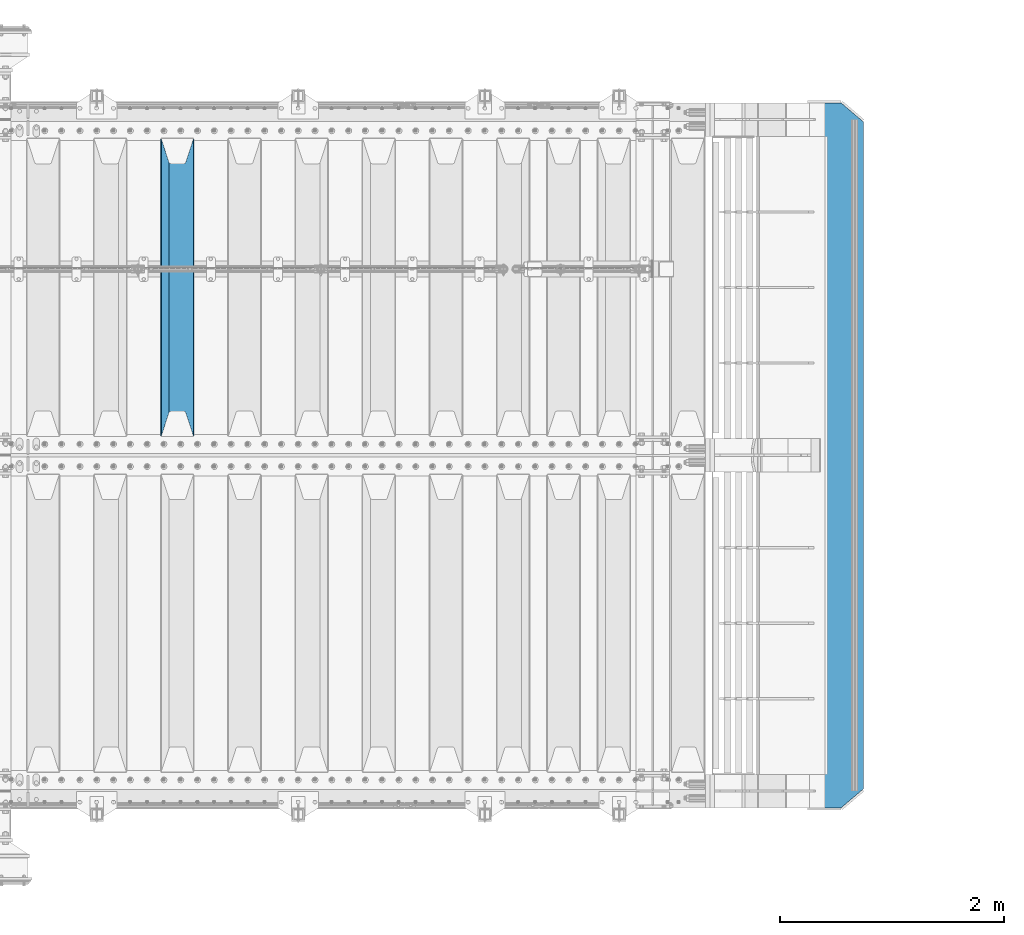
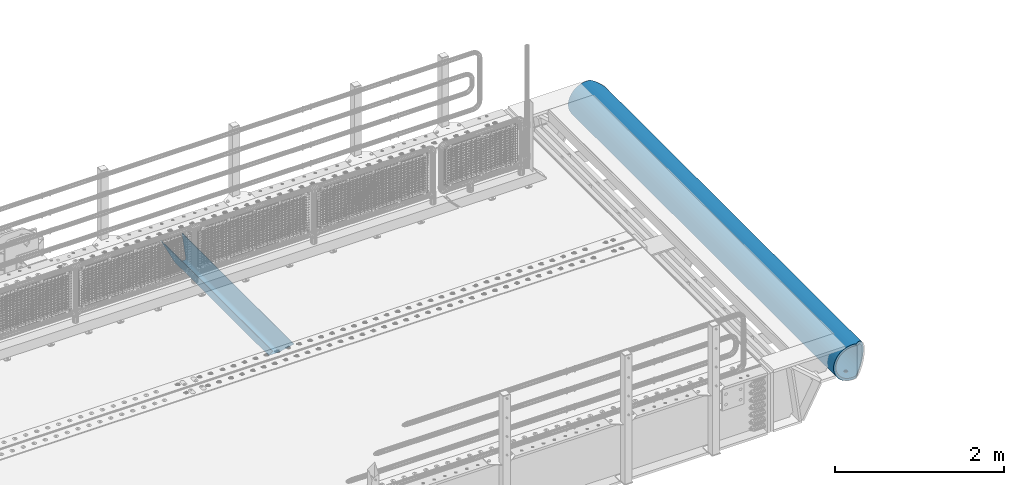
# One storey, part 132 of 242: 2 beams.
"""IFC2X3 building model written with IfcOpenShell, lengths in millimetres."""

from ifc_helpers import new_model, si_unit, frame, origin_with_axes, place, context, subcontext, project, spatial, faceted_brep, material, type_object, element, save


model = new_model("IFC2X3")

# Units and contexts
model_context = context("Model", 3, precision=1e-05, world=origin_with_axes())
body_context = subcontext(model_context, "Body", "Model", "MODEL_VIEW")
ifc_project = project(units=[si_unit("LENGTHUNIT", "METRE", prefix="MILLI"), si_unit("AREAUNIT", "SQUARE_METRE"), si_unit("VOLUMEUNIT", "CUBIC_METRE"), si_unit("MASSUNIT", "GRAM", prefix="KILO"), si_unit("TIMEUNIT", "SECOND"), si_unit("PLANEANGLEUNIT", "RADIAN"), si_unit("SOLIDANGLEUNIT", "STERADIAN"), si_unit("THERMODYNAMICTEMPERATUREUNIT", "DEGREE_CELSIUS"), si_unit("LUMINOUSINTENSITYUNIT", "LUMEN")], contexts=[model_context])

# Site, building, storey
site_placement = place(None, origin_with_axes())
site = spatial("IfcSite", under=ifc_project, at=site_placement, CompositionType="ELEMENT")
building_placement = place(site_placement, origin_with_axes())
building = spatial("IfcBuilding", under=site, at=building_placement, Name="Standard", CompositionType="ELEMENT")
storey_placement = place(building_placement, origin_with_axes())
storey = spatial("IfcBuildingStorey", under=building, at=storey_placement, Name="Undefined", CompositionType="ELEMENT", Elevation=0.0)

# Beams
ifc_material = material(Name="STEEL/S355N")
beam_type_1 = type_object("IfcBeamType", PredefinedType="NOTDEFINED")
beam_1_placement = place(storey_placement, frame((-26780.0, -20825.0, -115.0), z_axis=(0.0, 0.0, 1.0), x_axis=(0.0, 1.0, 0.0)))
element("IfcBeam", 1, at=beam_1_placement, inside=storey, type_object=beam_type_1, material=ifc_material, context=body_context, shape_type="Brep", body=[
    faceted_brep([(0.0, 150.0, 115.0), (0.0, 143.689999999999, 115.0), (2650.00000000297, 143.689999999999, 115.0), (2650.00000000297, 150.0, 115.0), (2650.00000000297, 142.059565218402, 110.000000003099), (2650.00000000297, 148.369565218403, 110.000000003099), (2441.90079219209, -80.1103600731112, -98.0992078077845), (2437.7588105432, -77.5672621345584, -102.241189456673), (2434.06523489747, -74.4080125315522, -105.934765102404), (2430.91086095089, -70.710272125576, -109.089139048974), (2428.37322971128, -66.5649389910068, -111.626770288588), (2426.51472138055, -62.0739139532889, -113.485278619323), (2425.38102192092, -57.3475956567672, -114.618978078955), (2424.99999999987, -52.5021667386536, -115.0), (2424.99999999987, 52.5021667386536, -115.0), (2425.38102192092, 57.3475956567672, -114.618978078955), (2426.51472138055, 62.0739139532889, -113.485278619323), (2428.37322971128, 66.5649389910068, -111.626770288588), (2430.91086095089, 70.710272125576, -109.089139048974), (2434.06523489747, 74.4080125315522, -105.934765102404), (2437.7588105432, 77.5672621345584, -102.241189456673), (2441.90079219209, 80.1103600731112, -98.0992078077846), (2446.38936140511, 81.9747917625791, -93.6106385947584), (2448.2494850041, 76.2713538057251, -91.7505149957729), (2444.62967112262, 74.76777986261, -95.3703288772456), (2441.28936334126, 72.7168944282894, -98.710636658607), (2438.31067330438, 70.1691124903846, -101.689326695487), (2435.76682334747, 67.1870637758839, -104.233176652398), (2433.72034654133, 63.8440531834895, -106.279653458539), (2432.22154950042, 60.222258798236, -107.778450499454), (2431.30727574265, 56.4107117849089, -108.692724257221), (2430.99999999987, 52.5031078186876, -109.0), (2430.99999999987, -52.5031078186876, -109.0), (2431.30727574265, -56.4107117849089, -108.692724257221), (2432.22154950042, -60.222258798236, -107.778450499454), (2433.72034654133, -63.8440531834895, -106.279653458539), (2435.76682334747, -67.1870637758839, -104.233176652398), (2438.31067330438, -70.1691124903846, -101.689326695487), (2441.28936334126, -72.7168944282894, -98.7106366586071), (2444.62967112262, -74.76777986261, -95.3703288772457), (2448.2494850041, -76.2713538057251, -91.7505149957729), (2650.00000000297, -142.059565218402, 110.000000003099), (2650.00000000297, -148.369565218403, 110.000000003099), (2446.38936140511, -81.9747917625791, -93.6106385947584), (2650.00000000297, -143.689999999999, 115.0), (2650.00000000297, -150.0, 115.0), (0.0, -143.689999999999, 115.0), (0.0, -150.0, 115.0), (0.0, -148.369565218261, 110.000000002669), (203.610638597427, -81.9747917625791, -93.6106385947584), (208.099207810454, -80.1103600731112, -98.0992078077845), (212.241189459342, -77.5672621345584, -102.241189456673), (215.934765105074, -74.4080125315522, -105.934765102404), (219.089139051644, -70.710272125576, -109.089139048974), (221.626770291256, -66.5649389910068, -111.626770288588), (223.485278621993, -62.0739139532889, -113.485278619323), (224.618978081624, -57.3475956567672, -114.618978078955), (225.00000000267, -52.5021667386536, -115.0), (225.00000000267, 52.5021667386536, -115.0), (224.618978081624, 57.3475956567672, -114.618978078955), (223.485278621993, 62.0739139532889, -113.485278619323), (221.626770291256, 66.5649389910068, -111.626770288588), (219.089139051644, 70.710272125576, -109.089139048974), (215.934765105074, 74.4080125315522, -105.934765102404), (212.241189459342, 77.5672621345584, -102.241189456673), (208.099207810454, 80.1103600731112, -98.0992078077846), (203.610638597427, 81.9747917625791, -93.6106385947584), (0.0, 148.369565218261, 110.000000002669), (0.0, 142.05956521826, 110.000000002669), (201.750514998443, 76.2713538057251, -91.7505149957729), (205.370328879915, 74.76777986261, -95.3703288772456), (208.710636661275, 72.7168944282894, -98.710636658607), (211.689326698157, 70.1691124903846, -101.689326695487), (214.233176655067, 67.1870637758839, -104.233176652398), (216.279653461206, 63.8440531834895, -106.279653458539), (217.778450502123, 60.222258798236, -107.778450499454), (218.69272425989, 56.4107117849089, -108.692724257221), (219.00000000267, 52.5031078186876, -109.0), (219.00000000267, -52.5031078186876, -109.0), (218.69272425989, -56.4107117849089, -108.692724257221), (217.778450502123, -60.222258798236, -107.778450499454), (216.279653461206, -63.8440531834895, -106.279653458539), (214.233176655067, -67.1870637758839, -104.233176652398), (211.689326698157, -70.1691124903846, -101.689326695487), (208.710636661275, -72.7168944282894, -98.7106366586071), (205.370328879915, -74.76777986261, -95.3703288772457), (201.750514998443, -76.2713538057251, -91.7505149957729), (0.0, -142.05956521826, 110.000000002669)], [[[0, 1, 2, 3]], [[3, 2, 4, 5]], [[6, 7, 8, 9, 10, 11, 12, 13, 14, 15, 16, 17, 18, 19, 20, 21, 22, 5, 4, 23, 24, 25, 26, 27, 28, 29, 30, 31, 32, 33, 34, 35, 36, 37, 38, 39, 40, 41, 42, 43]], [[44, 45, 42, 41]], [[46, 47, 45, 44]], [[43, 42, 45, 47, 48, 49]], [[6, 43, 49, 50]], [[7, 6, 50, 51]], [[8, 7, 51, 52]], [[9, 8, 52, 53]], [[10, 9, 53, 54]], [[11, 10, 54, 55]], [[12, 11, 55, 56]], [[13, 12, 56, 57]], [[14, 13, 57, 58]], [[15, 14, 58, 59]], [[16, 15, 59, 60]], [[17, 16, 60, 61]], [[18, 17, 61, 62]], [[19, 18, 62, 63]], [[20, 19, 63, 64]], [[21, 20, 64, 65]], [[22, 21, 65, 66]], [[0, 3, 5, 22, 66, 67]], [[1, 0, 67, 68]], [[23, 4, 2, 1, 68, 69]], [[24, 23, 69, 70]], [[25, 24, 70, 71]], [[26, 25, 71, 72]], [[27, 26, 72, 73]], [[28, 27, 73, 74]], [[29, 28, 74, 75]], [[30, 29, 75, 76]], [[31, 30, 76, 77]], [[32, 31, 77, 78]], [[33, 32, 78, 79]], [[34, 33, 79, 80]], [[35, 34, 80, 81]], [[36, 35, 81, 82]], [[37, 36, 82, 83]], [[38, 37, 83, 84]], [[39, 38, 84, 85]], [[40, 39, 85, 86]], [[46, 44, 41, 40, 86, 87]], [[47, 46, 87, 48]], [[86, 85, 84, 83, 82, 81, 80, 79, 78, 77, 76, 75, 74, 73, 72, 71, 70, 69, 68, 67, 66, 65, 64, 63, 62, 61, 60, 59, 58, 57, 56, 55, 54, 53, 52, 51, 50, 49, 48, 87]]]),
])
beam_type_2 = type_object("IfcBeamType", PredefinedType="NOTDEFINED")
beam_2_placement = place(storey_placement, frame((-20904.0011701094, -17850.0, -254.000000000001), z_axis=(0.0, 0.0, 1.0), x_axis=(0.0, -1.0, 0.0)))
element("IfcBeam", 2, at=beam_2_placement, inside=storey, type_object=beam_type_2, material=ifc_material, context=body_context, shape_type="Brep", body=[
    faceted_brep([(4659.56708580913, 23.1006844286749, -220.181936706646), (4659.56708580913, 23.1006844286749, -252.181936706647), (4667.67766952966, 17.6813656455561, -252.608446344705), (4667.67766952966, 17.6813656455561, -220.608446344705), (4673.09698831278, 9.57078192502013, -253.246763126855), (4673.09698831278, 9.57078192502013, -221.246763126855), (4675.0, 0.0, -254.0), (4675.0, 0.0, -222.0), (4673.09698831278, -9.5633896932377, -253.247344908113), (4673.09698831278, -9.5633896932377, -221.247344908113), (4667.67766952966, -17.6739734137736, -252.609028125962), (4667.67766952966, -17.6739734137736, -220.609028125963), (4659.56708580913, -23.0932921968924, -252.182518487904), (4659.56708580913, -23.0932921968924, -220.182518487905), (4650.0, -24.9963038841088, -252.032748220013), (4650.0, -24.9963038841088, -220.032748220014), (4640.43291419087, -23.0932921968924, -252.182518487904), (4640.43291419087, -23.0932921968924, -220.182518487905), (4632.32233047034, -17.6739734137736, -252.609028125962), (4632.32233047034, -17.6739734137736, -220.609028125963), (4626.90301168722, -9.5633896932377, -253.247344908113), (4626.90301168722, -9.5633896932377, -221.247344908113), (4625.0, 0.0, -254.0), (4625.0, 0.0, -222.0), (4626.90301168722, 9.57078192502013, -253.246763126855), (4626.90301168722, 9.57078192502013, -221.246763126855), (4632.32233047034, 17.6813656455561, -252.608446344705), (4632.32233047034, 17.6813656455561, -220.608446344705), (4640.43291419087, 23.1006844286749, -252.181936706647), (4640.43291419087, 23.1006844286749, -220.181936706646), (4650.0, 25.0036961158912, -252.032166438756), (4650.0, 25.0036961158912, -220.032166438756), (1632.32233047034, -17.6776695296612, -220.608737235334), (1632.32233047034, -17.6776695296612, -252.608737235334), (1626.90301168722, -9.56708580912527, -253.247054017484), (1626.90301168722, -9.56708580912527, -221.247054017484), (1640.43291419087, -23.09698831278, -220.182227597276), (1640.43291419087, -23.09698831278, -252.182227597276), (1650.0, -24.9999999999964, -220.032457329384), (1650.0, -24.9999999999964, -252.032457329385), (1659.56708580913, -23.09698831278, -220.182227597276), (1659.56708580913, -23.09698831278, -252.182227597276), (1667.67766952966, -17.6776695296612, -220.608737235334), (1667.67766952966, -17.6776695296612, -252.608737235334), (1673.09698831278, -9.56708580912527, -221.247054017484), (1673.09698831278, -9.56708580912527, -253.247054017484), (1675.0, 0.0, -222.0), (1675.0, 0.0, -254.0), (1673.09698831278, 9.56708580913255, -221.247054017483), (1673.09698831278, 9.56708580913255, -253.247054017484), (1667.67766952966, 17.6776695296685, -220.608737235333), (1667.67766952966, 17.6776695296685, -252.608737235334), (1659.56708580913, 23.0969883127873, -220.182227597275), (1659.56708580913, 23.0969883127873, -252.182227597275), (1650.0, 25.0000000000036, -220.032457329384), (1650.0, 25.0000000000036, -252.032457329384), (1640.43291419087, 23.0969883127873, -220.182227597275), (1640.43291419087, 23.0969883127873, -252.182227597275), (1632.32233047034, 17.6776695296685, -220.608737235333), (1632.32233047034, 17.6776695296685, -252.608737235334), (1626.90301168722, 9.56708580913255, -221.247054017483), (1626.90301168722, 9.56708580913255, -253.247054017484), (1625.0, 0.0, -222.0), (1625.0, 0.0, -254.0), (132.322330470335, -17.6776695296612, -220.608737235334), (132.322330470335, -17.6776695296612, -252.608737235334), (126.903011687216, -9.56708580912527, -253.247054017484), (126.903011687216, -9.56708580912527, -221.247054017484), (140.432914190871, -23.09698831278, -220.182227597276), (140.432914190871, -23.09698831278, -252.182227597276), (150.0, -24.9999999999964, -220.032457329385), (150.0, -24.9999999999964, -252.032457329385), (159.567085809129, -23.09698831278, -220.182227597276), (159.567085809129, -23.09698831278, -252.182227597276), (167.677669529665, -17.6776695296612, -220.608737235334), (167.677669529665, -17.6776695296612, -252.608737235334), (173.096988312784, -9.56708580912527, -221.247054017484), (173.096988312784, -9.56708580912527, -253.247054017484), (175.0, 0.0, -222.0), (175.0, 0.0, -254.0), (173.096988312784, 9.56708580913255, -221.247054017484), (173.096988312784, 9.56708580913255, -253.247054017484), (167.677669529665, 17.6776695296685, -220.608737235333), (167.677669529665, 17.6776695296685, -252.608737235333), (159.567085809129, 23.0969883127873, -220.182227597275), (159.567085809129, 23.0969883127873, -252.182227597275), (150.0, 25.0000000000036, -220.032457329384), (150.0, 25.0000000000036, -252.032457329384), (140.432914190871, 23.0969883127873, -220.182227597275), (140.432914190871, 23.0969883127873, -252.182227597275), (132.322330470335, 17.6776695296685, -220.608737235333), (132.322330470335, 17.6776695296685, -252.608737235333), (126.903011687216, 9.56708580913255, -221.247054017484), (126.903011687216, 9.56708580913255, -253.247054017484), (125.0, 0.0, -222.0), (125.0, 0.0, -254.0), (0.0, -34.7284512389306, -219.266811612121), (0.0, -68.6017727512371, -211.134546617524), (6300.0, -68.6017727512371, -211.134546617524), (6300.0, -34.7284512389306, -219.266811612121), (0.0, -100.785890942181, -197.803448369818), (6300.0, -100.785890942181, -197.803448369818), (0.0, -130.48832600893, -179.601772751238), (6300.0, -130.48832600893, -179.601772751238), (0.0, -156.977705423415, -156.977705423414), (6300.0, -156.977705423415, -156.977705423414), (0.0, -179.601772751237, -130.488326008929), (6300.0, -179.601772751237, -130.488326008929), (0.0, -197.803448369817, -100.785890942179), (6300.0, -197.803448369817, -100.785890942179), (0.0, -211.134546617523, -68.6017727512383), (6300.0, -211.134546617523, -68.6017727512383), (0.0, -219.26681161212, -34.7284512389313), (6300.0, -219.26681161212, -34.7284512389313), (0.0, -222.0, 0.0), (6300.0, -222.0, 0.0), (0.0, -219.26681161212, 34.7284512389313), (6300.0, -219.26681161212, 34.7284512389313), (0.0, -211.134546617523, 68.6017727512384), (6300.0, -211.134546617523, 68.6017727512384), (0.0, -197.803448369817, 100.785890942179), (6300.0, -197.803448369817, 100.785890942179), (0.0, -179.601772751237, 130.488326008929), (6300.0, -179.601772751237, 130.488326008929), (0.0, -156.977705423415, 156.977705423414), (6300.0, -156.977705423415, 156.977705423414), (0.0, -130.48832600893, 179.601772751238), (6300.0, -130.48832600893, 179.601772751238), (0.0, -100.785890942181, 197.803448369818), (6300.0, -100.785890942181, 197.803448369818), (0.0, -68.6017727512371, 211.134546617524), (6300.0, -68.6017727512371, 211.134546617524), (0.0, -34.7284512389306, 219.266811612121), (6300.0, -34.7284512389306, 219.266811612121), (0.0, 0.0, 222.0), (6300.0, 0.0, 222.0), (0.0, 34.7284512389306, 219.266811612121), (6300.0, 34.7284512389306, 219.266811612121), (6287.59163509751, 68.6017727512371, 211.134546617524), (6300.0, 54.0036961158912, 214.639234741094), (0.0, 54.0000000000036, 214.64012210001), (12.4115067427265, 68.6017727512371, 211.134546617524), (6260.23513515894, 100.785890942181, 197.803448369818), (39.7680069938215, 100.785890942181, 197.803448369818), (6234.98806583554, 130.48832600893, 179.601772751238), (65.0150766056395, 130.48832600893, 179.601772751238), (6212.47209376429, 156.977705423415, 156.977705423414), (87.5310489341173, 156.977705423415, 156.977705423414), (6193.2416369038, 179.601772751237, 130.488326008929), (106.7615060143, 179.601772751237, 130.488326008929), (6177.7702129242, 197.803448369817, 100.785890942179), (122.232930170641, 197.803448369817, 100.785890942179), (6166.43877963059, 211.134546617523, 68.6017727512383), (133.564363593712, 211.134546617523, 68.6017727512383), (6159.52635451751, 219.26681161212, 34.7284512389312), (140.476788785749, 219.26681161212, 34.7284512389312), (6157.20314443229, 222.0, -2.8421709430404e-14), (142.799998897513, 222.0, -2.8421709430404e-14), (6159.52635451751, 219.26681161212, -34.7284512389313), (140.476788785749, 219.26681161212, -34.7284512389313), (6166.43877963059, 211.134546617523, -68.6017727512383), (133.564363593712, 211.134546617523, -68.6017727512383), (6177.7702129242, 197.803448369817, -100.785890942179), (122.232930170641, 197.803448369817, -100.785890942179), (6193.2416369038, 179.601772751237, -130.488326008929), (106.7615060143, 179.601772751237, -130.488326008929), (6212.47209376429, 156.977705423415, -156.977705423414), (87.5310489341173, 156.977705423415, -156.977705423414), (6234.98806583554, 130.48832600893, -179.601772751238), (65.0150766056395, 130.48832600893, -179.601772751238), (6260.23513515894, 100.785890942181, -197.803448369818), (39.7680069938215, 100.785890942181, -197.803448369818), (6287.59163509751, 68.6017727512371, -211.134546617524), (12.4115067427265, 68.6017727512371, -211.134546617524), (0.0, 34.7284512389306, -219.266811612121), (6300.0, 34.7284512389306, -219.266811612121), (6300.0, 54.0036961158912, -214.639234741094), (0.0, 54.0000000000036, -214.64012210001), (6140.5700428826, 241.56835513897, -78.4903165712366), (6153.53483593025, 226.315657143845, -115.313586933845), (146.468307441461, 226.315657143845, -115.313586933845), (159.433100637219, 241.56835513897, -78.4903165712366), (6171.23637507808, 205.490316571235, -149.297454082288), (128.766768091402, 205.490316571235, -149.297454082288), (6193.23878968423, 179.605122421384, -179.605122421383), (106.764353233899, 179.605122421384, -179.605122421383), (6219.00030727927, 149.297454082287, -205.490316571237), (81.0028353445596, 149.297454082287, -205.490316571237), (6247.88659380243, 115.313586933844, -226.315657143845), (52.1165484913981, 115.313586933844, -226.315657143845), (6279.18637301142, 78.4903165712349, -241.568355138969), (20.8167689248294, 78.4903165712349, -241.568355138969), (6300.0, 54.0036961158912, -247.447072591954), (6300.0, 39.7343541202172, -250.872838511165), (0.0, 39.7343541202172, -250.872838511165), (0.0, 54.0000000000036, -247.447959950869), (0.0, 0.0, -222.0), (0.0, 0.0, -254.0), (0.0, -39.7343541202172, -250.872838511165), (0.0, -78.4903165712349, -241.568355138969), (0.0, -115.313586933844, -226.315657143845), (0.0, -149.297454082287, -205.490316571237), (0.0, -179.605122421384, -179.605122421383), (0.0, -205.490316571235, -149.297454082288), (0.0, -226.315657143845, -115.313586933845), (0.0, -241.56835513897, -78.4903165712367), (0.0, -250.872838511164, -39.7343541202187), (0.0, -254.0, 0.0), (0.0, -250.872838511164, 39.7343541202187), (0.0, -241.56835513897, 78.4903165712366), (0.0, -226.315657143845, 115.313586933845), (0.0, -205.490316571235, 149.297454082288), (0.0, -179.605122421384, 179.605122421383), (0.0, -149.297454082287, 205.490316571237), (0.0, -115.313586933844, 226.315657143845), (0.0, -78.4903165712349, 241.568355138969), (0.0, -39.7343541202172, 250.872838511165), (0.0, 0.0, 254.0), (0.0, 39.7343541202172, 250.872838511165), (0.0, 54.0000000000036, 247.447959950869), (6300.0, -39.7343541202172, -250.872838511165), (6300.0, -78.4903165712349, -241.568355138969), (6300.0, -115.313586933844, -226.315657143845), (6300.0, -149.297454082287, -205.490316571237), (6300.0, -179.605122421384, -179.605122421383), (6300.0, -205.490316571235, -149.297454082288), (6300.0, -226.315657143845, -115.313586933845), (6300.0, -241.56835513897, -78.4903165712367), (6300.0, -250.872838511164, -39.7343541202187), (6300.0, -254.0, 0.0), (6300.0, -250.872838511164, 39.7343541202187), (6300.0, -241.56835513897, 78.4903165712366), (6300.0, -226.315657143845, 115.313586933845), (6300.0, -205.490316571235, 149.297454082288), (6300.0, -179.605122421384, 179.605122421383), (6300.0, -149.297454082287, 205.490316571237), (6300.0, -115.313586933844, 226.315657143845), (6300.0, -78.4903165712349, 241.568355138969), (6300.0, -39.7343541202172, 250.872838511165), (6300.0, 0.0, 254.0), (6300.0, 39.7343541202172, 250.872838511165), (6300.0, 54.0036961158912, 247.447072591954), (6279.18637301142, 78.4903165712349, 241.568355138969), (20.8167689248294, 78.4903165712349, 241.568355138969), (6247.88659380243, 115.313586933844, 226.315657143845), (52.1165484913981, 115.313586933844, 226.315657143845), (6219.00030727927, 149.297454082287, 205.490316571237), (81.0028353445596, 149.297454082287, 205.490316571237), (6193.23878968423, 179.605122421384, 179.605122421383), (106.764353233899, 179.605122421384, 179.605122421383), (6171.23637507808, 205.490316571235, 149.297454082288), (128.766768091402, 205.490316571235, 149.297454082288), (6153.53483593025, 226.315657143845, 115.313586933845), (146.468307441461, 226.315657143845, 115.313586933845), (6140.5700428826, 241.56835513897, 78.4903165712367), (159.433100637219, 241.56835513897, 78.4903165712367), (6129.99999983226, 254.003700142144, 0.0), (6132.66123216764, 250.872838511164, -39.7343541202186), (167.341911442527, 250.872838511164, -39.7343541202186), (170.000001295226, 254.000003067897, 5.6843418860808e-14), (6132.66123216764, 250.872838511164, 39.7343541202187), (167.341911442527, 250.872838511164, 39.7343541202187), (6300.0, 0.0, -254.0), (6300.0, 0.0, -222.0), (6132.32233047034, -17.6739734137809, -220.609028125962), (6132.32233047034, -17.6739734137809, -252.609028125962), (6126.90301168722, -9.56338969324497, -253.247344908112), (6126.90301168722, -9.56338969324497, -221.247344908113), (6140.43291419087, -23.0932921968997, -220.182518487904), (6140.43291419087, -23.0932921968997, -252.182518487904), (6150.0, -24.9963038841161, -220.032748220013), (6150.0, -24.9963038841161, -252.032748220013), (6159.56708580913, -23.0932921968997, -220.182518487904), (6159.56708580913, -23.0932921968997, -252.182518487904), (6167.67766952966, -17.6739734137809, -220.609028125962), (6167.67766952966, -17.6739734137809, -252.609028125962), (6173.09698831278, -9.56338969324497, -221.247344908113), (6173.09698831278, -9.56338969324497, -253.247344908112), (6175.0, 0.0, -222.0), (6175.0, 0.0, -254.0), (6173.09698831278, 9.57078192501285, -221.246763126855), (6173.09698831278, 9.57078192501285, -253.246763126856), (6167.67766952966, 17.6813656455488, -220.608446344705), (6167.67766952966, 17.6813656455488, -252.608446344706), (6159.56708580913, 23.1006844286676, -220.181936706647), (6159.56708580913, 23.1006844286676, -252.181936706648), (6150.0, 25.0036961158839, -220.032166438756), (6150.0, 25.0036961158839, -252.032166438756), (6140.43291419087, 23.1006844286676, -220.181936706647), (6140.43291419087, 23.1006844286676, -252.181936706648), (6132.32233047034, 17.6813656455488, -220.608446344705), (6132.32233047034, 17.6813656455488, -252.608446344706), (6126.90301168722, 9.57078192501285, -221.246763126855), (6126.90301168722, 9.57078192501285, -253.246763126856), (6125.0, 0.0, -222.0), (6125.0, 0.0, -254.0), (3175.0, 0.0, -222.0), (3173.09698831278, -9.56708580912527, -221.247054017485), (3167.67766952966, -17.6776695296612, -220.608737235334), (3159.56708580913, -23.09698831278, -220.182227597276), (3150.0, -24.9999999999964, -220.032457329385), (3140.43291419087, -23.09698831278, -220.182227597276), (3132.32233047034, -17.6776695296612, -220.608737235334), (3126.90301168722, -9.56708580912527, -221.247054017485), (3125.0, 0.0, -222.0), (3126.90301168722, 9.56708580913255, -221.247054017483), (3132.32233047034, 17.6776695296685, -220.608737235333), (3140.43291419087, 23.0969883127873, -220.182227597275), (3150.0, 25.0000000000036, -220.032457329384), (3159.56708580913, 23.0969883127873, -220.182227597275), (3167.67766952966, 17.6776695296685, -220.608737235333), (3173.09698831278, 9.56708580913255, -221.247054017483), (3173.09698831278, 9.56708580913255, -253.247054017483), (3175.0, 0.0, -254.0), (3167.67766952966, 17.6776695296685, -252.608737235333), (3159.56708580913, 23.0969883127873, -252.182227597275), (3150.0, 25.0000000000036, -252.032457329384), (3140.43291419087, 23.0969883127873, -252.182227597275), (3132.32233047034, 17.6776695296685, -252.608737235333), (3126.90301168722, 9.56708580913255, -253.247054017483), (3125.0, 0.0, -254.0), (3126.90301168722, -9.56708580912527, -253.247054017484), (3132.32233047034, -17.6776695296612, -252.608737235334), (3140.43291419087, -23.09698831278, -252.182227597276), (3150.0, -24.9999999999964, -252.032457329385), (3159.56708580913, -23.09698831278, -252.182227597276), (3167.67766952966, -17.6776695296612, -252.608737235334), (3173.09698831278, -9.56708580912527, -253.247054017484)], [[[0, 1, 2, 3]], [[3, 2, 4, 5]], [[5, 4, 6, 7]], [[7, 6, 8, 9]], [[9, 8, 10, 11]], [[11, 10, 12, 13]], [[13, 12, 14, 15]], [[15, 14, 16, 17]], [[17, 16, 18, 19]], [[19, 18, 20, 21]], [[21, 20, 22, 23]], [[23, 22, 24, 25]], [[25, 24, 26, 27]], [[27, 26, 28, 29]], [[29, 28, 30, 31]], [[31, 30, 1, 0]], [[32, 33, 34, 35]], [[36, 37, 33, 32]], [[38, 39, 37, 36]], [[40, 41, 39, 38]], [[42, 43, 41, 40]], [[44, 45, 43, 42]], [[46, 47, 45, 44]], [[48, 49, 47, 46]], [[50, 51, 49, 48]], [[52, 53, 51, 50]], [[54, 55, 53, 52]], [[56, 57, 55, 54]], [[58, 59, 57, 56]], [[60, 61, 59, 58]], [[62, 63, 61, 60]], [[35, 34, 63, 62]], [[64, 65, 66, 67]], [[68, 69, 65, 64]], [[70, 71, 69, 68]], [[72, 73, 71, 70]], [[74, 75, 73, 72]], [[76, 77, 75, 74]], [[78, 79, 77, 76]], [[80, 81, 79, 78]], [[82, 83, 81, 80]], [[84, 85, 83, 82]], [[86, 87, 85, 84]], [[88, 89, 87, 86]], [[90, 91, 89, 88]], [[92, 93, 91, 90]], [[94, 95, 93, 92]], [[67, 66, 95, 94]], [[96, 97, 98, 99]], [[97, 100, 101, 98]], [[100, 102, 103, 101]], [[102, 104, 105, 103]], [[104, 106, 107, 105]], [[106, 108, 109, 107]], [[108, 110, 111, 109]], [[110, 112, 113, 111]], [[112, 114, 115, 113]], [[114, 116, 117, 115]], [[116, 118, 119, 117]], [[118, 120, 121, 119]], [[120, 122, 123, 121]], [[122, 124, 125, 123]], [[124, 126, 127, 125]], [[126, 128, 129, 127]], [[128, 130, 131, 129]], [[130, 132, 133, 131]], [[132, 134, 135, 133]], [[134, 136, 137, 135]], [[138, 139, 137, 136, 140, 141]], [[142, 138, 141, 143]], [[144, 142, 143, 145]], [[146, 144, 145, 147]], [[148, 146, 147, 149]], [[150, 148, 149, 151]], [[152, 150, 151, 153]], [[154, 152, 153, 155]], [[156, 154, 155, 157]], [[158, 156, 157, 159]], [[160, 158, 159, 161]], [[162, 160, 161, 163]], [[164, 162, 163, 165]], [[166, 164, 165, 167]], [[168, 166, 167, 169]], [[170, 168, 169, 171]], [[172, 170, 171, 173]], [[174, 175, 176, 172, 173, 177]], [[178, 179, 180, 181]], [[179, 182, 183, 180]], [[182, 184, 185, 183]], [[184, 186, 187, 185]], [[186, 188, 189, 187]], [[188, 190, 191, 189]], [[190, 192, 193, 194, 195, 191]], [[136, 134, 132, 130, 128, 126, 124, 122, 120, 118, 116, 114, 112, 110, 108, 106, 104, 102, 100, 97, 96, 196, 174, 177, 195, 194, 197, 198, 199, 200, 201, 202, 203, 204, 205, 206, 207, 208, 209, 210, 211, 212, 213, 214, 215, 216, 217, 218, 219, 140]], [[199, 198, 220, 221]], [[200, 199, 221, 222]], [[201, 200, 222, 223]], [[202, 201, 223, 224]], [[203, 202, 224, 225]], [[204, 203, 225, 226]], [[205, 204, 226, 227]], [[206, 205, 227, 228]], [[207, 206, 228, 229]], [[208, 207, 229, 230]], [[209, 208, 230, 231]], [[210, 209, 231, 232]], [[211, 210, 232, 233]], [[212, 211, 233, 234]], [[213, 212, 234, 235]], [[214, 213, 235, 236]], [[215, 214, 236, 237]], [[216, 215, 237, 238]], [[217, 216, 238, 239]], [[218, 217, 239, 240]], [[218, 240, 241, 242, 243, 219]], [[242, 244, 245, 243]], [[244, 246, 247, 245]], [[246, 248, 249, 247]], [[248, 250, 251, 249]], [[250, 252, 253, 251]], [[252, 254, 255, 253]], [[256, 257, 258, 259]], [[260, 256, 259, 261]], [[254, 260, 261, 255]], [[259, 258, 181, 180, 183, 185, 187, 189, 191, 195, 177, 173, 171, 169, 167, 165, 163, 161, 159, 157, 155, 153, 151, 149, 147, 145, 143, 141, 140, 219, 243, 245, 247, 249, 251, 253, 255, 261]], [[257, 178, 181, 258]], [[256, 260, 254, 252, 250, 248, 246, 244, 242, 241, 139, 138, 142, 144, 146, 148, 150, 152, 154, 156, 158, 160, 162, 164, 166, 168, 170, 172, 176, 192, 190, 188, 186, 184, 182, 179, 178, 257]], [[240, 239, 238, 237, 236, 235, 234, 233, 232, 231, 230, 229, 228, 227, 226, 225, 224, 223, 222, 221, 220, 262, 193, 192, 176, 175, 263, 99, 98, 101, 103, 105, 107, 109, 111, 113, 115, 117, 119, 121, 123, 125, 127, 129, 131, 133, 135, 137, 139, 241]], [[264, 265, 266, 267]], [[268, 269, 265, 264]], [[270, 271, 269, 268]], [[272, 273, 271, 270]], [[274, 275, 273, 272]], [[276, 277, 275, 274]], [[278, 279, 277, 276]], [[280, 281, 279, 278]], [[282, 283, 281, 280]], [[284, 285, 283, 282]], [[286, 287, 285, 284]], [[288, 289, 287, 286]], [[290, 291, 289, 288]], [[292, 293, 291, 290]], [[294, 295, 293, 292]], [[267, 266, 295, 294]], [[296, 297, 298, 299, 300, 301, 302, 303, 304, 46, 44, 42, 40, 38, 36, 32, 35, 62, 78, 76, 74, 72, 70, 68, 64, 67, 94, 196, 96, 99, 263, 278, 276, 274, 272, 270, 268, 264, 267, 294, 7, 9, 11, 13, 15, 17, 19, 21, 23]], [[3, 5, 7, 294, 292, 290, 288, 286, 284, 282, 280, 278, 263, 175, 174, 196, 94, 92, 90, 88, 86, 84, 82, 80, 78, 62, 60, 58, 56, 54, 52, 50, 48, 46, 304, 305, 306, 307, 308, 309, 310, 311, 296, 23, 25, 27, 29, 31, 0]], [[311, 312, 313, 296]], [[310, 314, 312, 311]], [[309, 315, 314, 310]], [[308, 316, 315, 309]], [[307, 317, 316, 308]], [[306, 318, 317, 307]], [[305, 319, 318, 306]], [[304, 320, 319, 305]], [[303, 321, 320, 304]], [[302, 322, 321, 303]], [[301, 323, 322, 302]], [[300, 324, 323, 301]], [[299, 325, 324, 300]], [[298, 326, 325, 299]], [[297, 327, 326, 298]], [[296, 313, 327, 297]], [[18, 16, 14, 12, 10, 8, 6, 295, 266, 265, 269, 271, 273, 275, 277, 279, 262, 220, 198, 197, 95, 66, 65, 69, 71, 73, 75, 77, 79, 63, 34, 33, 37, 39, 41, 43, 45, 47, 320, 321, 322, 323, 324, 325, 326, 327, 313, 22, 20]], [[26, 24, 22, 313, 312, 314, 315, 316, 317, 318, 319, 320, 47, 49, 51, 53, 55, 57, 59, 61, 63, 79, 81, 83, 85, 87, 89, 91, 93, 95, 197, 194, 193, 262, 279, 281, 283, 285, 287, 289, 291, 293, 295, 6, 4, 2, 1, 30, 28]]]),
])

save(model, "model.ifc")
